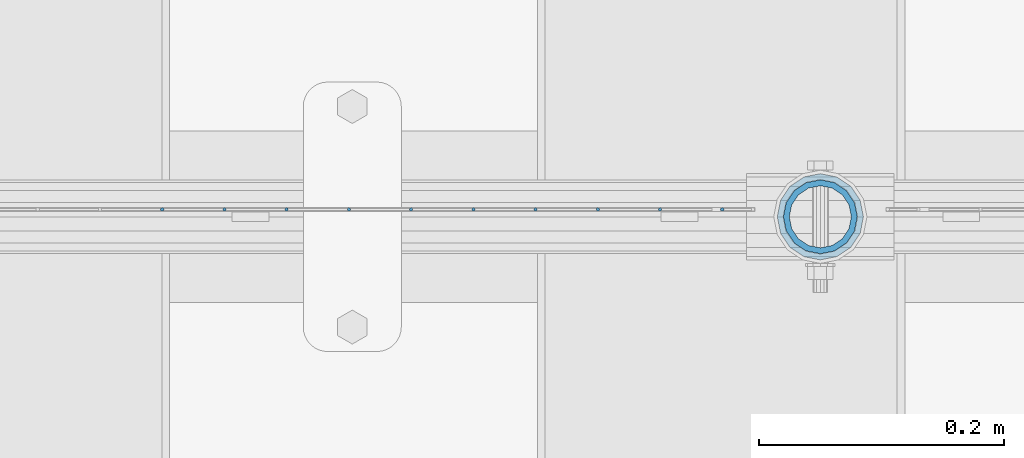
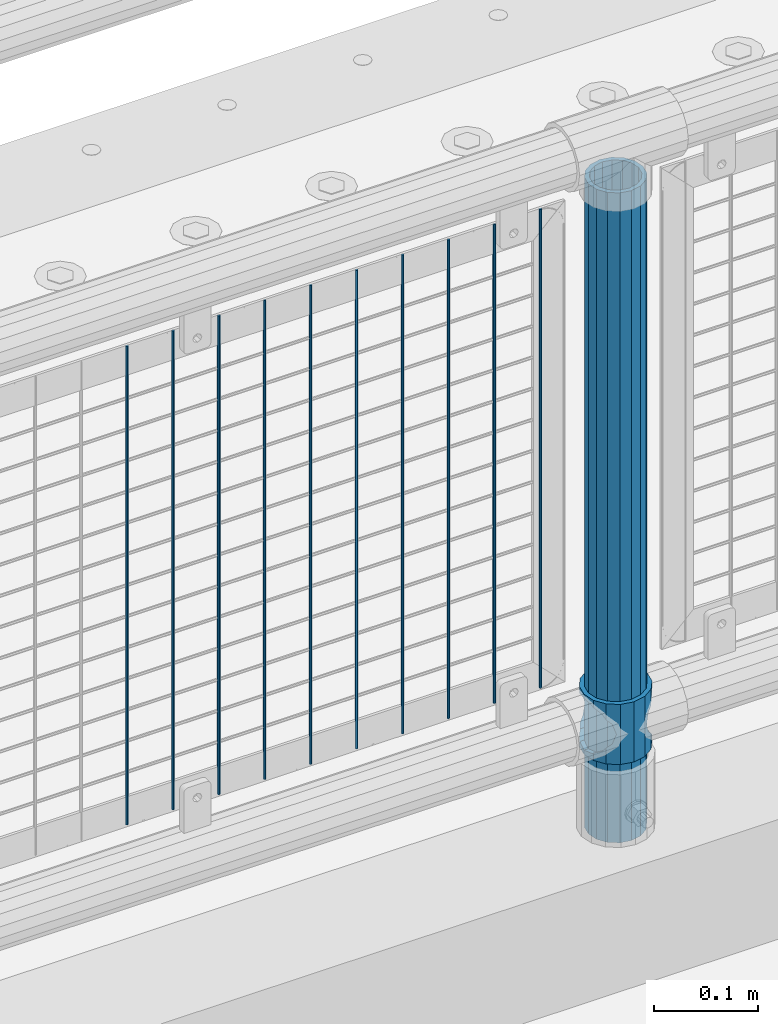
# One storey, part 99 of 242: 12 columns.
"""IFC2X3 building model written with IfcOpenShell, lengths in millimetres."""

from ifc_helpers import new_model, si_unit, frame, origin_with_axes, place, context, subcontext, project, spatial, faceted_brep, material, type_object, element, save


model = new_model("IFC2X3")

# Units and contexts
model_context = context("Model", 3, precision=1e-05, world=origin_with_axes())
body_context = subcontext(model_context, "Body", "Model", "MODEL_VIEW")
ifc_project = project(units=[si_unit("LENGTHUNIT", "METRE", prefix="MILLI"), si_unit("AREAUNIT", "SQUARE_METRE"), si_unit("VOLUMEUNIT", "CUBIC_METRE"), si_unit("MASSUNIT", "GRAM", prefix="KILO"), si_unit("TIMEUNIT", "SECOND"), si_unit("PLANEANGLEUNIT", "RADIAN"), si_unit("SOLIDANGLEUNIT", "STERADIAN"), si_unit("THERMODYNAMICTEMPERATUREUNIT", "DEGREE_CELSIUS"), si_unit("LUMINOUSINTENSITYUNIT", "LUMEN")], contexts=[model_context])

# Site, building, storey
site_placement = place(None, origin_with_axes())
site = spatial("IfcSite", under=ifc_project, at=site_placement, CompositionType="ELEMENT")
building_placement = place(site_placement, origin_with_axes())
building = spatial("IfcBuilding", under=site, at=building_placement, Name="Standard", CompositionType="ELEMENT")
storey_placement = place(building_placement, origin_with_axes())
storey = spatial("IfcBuildingStorey", under=building, at=storey_placement, Name="Undefined", CompositionType="ELEMENT", Elevation=0.0)

# Columns
ifc_material_1 = material()
column_type_1 = type_object("IfcColumnType", PredefinedType="NOTDEFINED")
column_1_placement = place(storey_placement, frame((-25499.0, -19335.5, 168.02), z_axis=(-1.0, 0.0, 0.0), x_axis=(0.0, 0.0, 1.0)))
element("IfcColumn", 1, at=column_1_placement, inside=storey, type_object=column_type_1, material=ifc_material_1, context=body_context, shape_type="Brep", body=[
    faceted_brep([(0.0, -25.3499999999985, 0.0), (0.0, -23.4203461491597, 9.70102501045403), (760.0, -23.4203461491597, 9.70102501045403), (760.0, -25.3499999999985, 0.0), (0.0, -17.9251569030785, 17.9251569030785), (760.0, -17.9251569030785, 17.9251569030785), (0.0, -9.70102501045403, 23.4203461491597), (760.0, -9.70102501045403, 23.4203461491597), (0.0, 0.0, 25.3499999999985), (760.0, 0.0, 25.3499999999985), (0.0, 9.70102501045403, 23.4203461491597), (760.0, 9.70102501045403, 23.4203461491597), (0.0, 17.9251569030785, 17.9251569030785), (760.0, 17.9251569030785, 17.9251569030785), (0.0, 23.4203461491597, 9.70102501045403), (760.0, 23.4203461491597, 9.70102501045403), (0.0, 25.3499999999985, 0.0), (760.0, 25.3499999999985, 0.0), (0.0, 23.4203461491597, -9.70102501045403), (760.0, 23.4203461491597, -9.70102501045403), (0.0, 17.9251569030785, -17.9251569030785), (760.0, 17.9251569030785, -17.9251569030785), (0.0, 9.70102501045403, -23.4203461491597), (760.0, 9.70102501045403, -23.4203461491597), (0.0, 0.0, -25.3499999999985), (760.0, 0.0, -25.3499999999985), (0.0, -9.70102501045403, -23.4203461491597), (760.0, -9.70102501045403, -23.4203461491597), (0.0, -17.9251569030785, -17.9251569030785), (760.0, -17.9251569030785, -17.9251569030785), (0.0, -23.4203461491597, -9.70102501045403), (760.0, -23.4203461491597, -9.70102501045403), (0.0, -30.1500000000015, 0.0), (0.0, -27.8549679052157, -11.5379054858058), (760.0, -27.8549679052157, -11.5379054858058), (760.0, -30.1500000000015, 0.0), (0.0, -21.3192694527752, -21.3192694527752), (760.0, -21.3192694527752, -21.3192694527752), (0.0, -11.5379054858058, -27.8549679052157), (760.0, -11.5379054858058, -27.8549679052157), (0.0, 0.0, -30.1500000000015), (760.0, 0.0, -30.1500000000015), (0.0, 11.5379054858058, -27.8549679052157), (760.0, 11.5379054858058, -27.8549679052157), (0.0, 21.3192694527752, -21.3192694527752), (760.0, 21.3192694527752, -21.3192694527752), (0.0, 27.8549679052157, -11.5379054858058), (760.0, 27.8549679052157, -11.5379054858058), (0.0, 30.1500000000015, 0.0), (760.0, 30.1500000000015, 0.0), (0.0, 27.8549679052157, 11.5379054858058), (760.0, 27.8549679052157, 11.5379054858058), (0.0, 21.3192694527752, 21.3192694527752), (760.0, 21.3192694527752, 21.3192694527752), (0.0, 11.5379054858058, 27.8549679052157), (760.0, 11.5379054858058, 27.8549679052157), (0.0, 0.0, 30.1500000000015), (760.0, 0.0, 30.1500000000015), (0.0, -11.5379054858058, 27.8549679052157), (760.0, -11.5379054858058, 27.8549679052157), (0.0, -21.3192694527752, 21.3192694527752), (760.0, -21.3192694527752, 21.3192694527752), (0.0, -27.8549679052157, 11.5379054858058), (760.0, -27.8549679052157, 11.5379054858058)], [[[0, 1, 2, 3]], [[1, 4, 5, 2]], [[4, 6, 7, 5]], [[6, 8, 9, 7]], [[8, 10, 11, 9]], [[10, 12, 13, 11]], [[12, 14, 15, 13]], [[14, 16, 17, 15]], [[16, 18, 19, 17]], [[18, 20, 21, 19]], [[20, 22, 23, 21]], [[22, 24, 25, 23]], [[24, 26, 27, 25]], [[26, 28, 29, 27]], [[28, 30, 31, 29]], [[30, 0, 3, 31]], [[32, 33, 34, 35]], [[33, 36, 37, 34]], [[36, 38, 39, 37]], [[38, 40, 41, 39]], [[40, 42, 43, 41]], [[42, 44, 45, 43]], [[44, 46, 47, 45]], [[46, 48, 49, 47]], [[48, 50, 51, 49]], [[50, 52, 53, 51]], [[52, 54, 55, 53]], [[54, 56, 57, 55]], [[56, 58, 59, 57]], [[58, 60, 61, 59]], [[60, 62, 63, 61]], [[62, 32, 35, 63]], [[37, 39, 41, 43, 45, 47, 49, 51, 53, 55, 57, 59, 61, 63, 35, 34], [5, 7, 9, 11, 13, 15, 17, 19, 21, 23, 25, 27, 29, 31, 3, 2]], [[62, 60, 58, 56, 54, 52, 50, 48, 46, 44, 42, 40, 38, 36, 33, 32], [30, 28, 26, 24, 22, 20, 18, 16, 14, 12, 10, 8, 6, 4, 1, 0]]]),
])
ifc_material_2 = material(Name="Misc_Undefined")
column_type_2 = type_object("IfcColumnType", PredefinedType="NOTDEFINED")
column_2_placement = place(storey_placement, frame((-25499.0, -19335.5, 263.02), z_axis=(-1.0, 0.0, 0.0), x_axis=(0.0, 0.0, 1.0)))
element("IfcColumn", 2, at=column_2_placement, inside=storey, type_object=column_type_2, material=ifc_material_2, context=body_context, shape_type="Brep", body=[
    faceted_brep([(63.1897438117172, 11.614442172282, -32.8397438117245), (63.1897438117172, 11.614442172282, -28.0397438117143), (56.6106908090114, 21.46069080901, -21.4606908090136), (56.6106908090114, 21.46069080901, -27.1226768591077), (61.9623795176744, 13.4513226476338, -32.4743655677739), (46.7644421722801, 28.0397438117179, -11.6144421722784), (46.7644421722801, 28.0397438117179, -20.0882031229849), (51.5310424080006, 24.8548033587067, -24.8548033587067), (35.1500000000015, 30.35, 0.0), (35.1499999999996, 30.3499999999985, -16.6306603983685), (23.5355578277192, 28.0397438117179, -11.6144421722784), (23.5355578277192, 28.0397438117179, -20.0882031229849), (18.7689575919987, 24.8548033587067, -24.8548033587067), (13.6893091909879, 21.46069080901, -21.4606908090136), (13.6893091909879, 21.46069080901, -27.1226768591077), (8.33762048232262, 13.4513226476338, -32.4743655677739), (7.11025618828211, 11.614442172282, -28.0397438117143), (7.11025618828211, 11.614442172282, -32.8397438117245), (4.79999999999961, 0.0, -30.3499999999985), (4.79999999999961, 0.0, -35.1500000000015), (7.11025618828211, -11.614442172282, -28.0397438117143), (7.11025618828211, -11.614442172282, -32.8397438117172), (13.6893091909879, -21.46069080901, -21.4606908090136), (13.6893091909879, -21.46069080901, -27.1226768591077), (8.33762048232484, -13.4513226476338, -32.4743655677739), (23.5355578277191, -28.0397438117179, -11.6144421722784), (23.5355578277191, -28.0397438117179, -20.0882031229921), (18.7689575919975, -24.8548033587067, -24.8548033587067), (35.1500000000015, -30.35, 0.0), (35.1499999999996, -30.3499999999985, -16.6306603983758), (46.7644421722801, -28.0397438117179, -11.6144421722784), (46.7644421722801, -28.0397438117179, -20.0882031229921), (51.5310424079973, -24.8548033587067, -24.8548033587067), (56.6106908090114, -21.46069080901, -21.4606908090136), (56.6106908090114, -21.46069080901, -27.1226768591077), (61.9623795176767, -13.4513226476338, -32.4743655677739), (63.1897438117172, -11.614442172282, -28.0397438117143), (63.1897438117172, -11.614442172282, -32.8397438117172), (65.4999999999997, 0.0, -30.3499999999985), (65.4999999999997, 0.0, -35.1500000000015), (0.0, -28.0397438117179, -11.6144421722784), (0.0, -30.3499999999985, 0.0), (0.0, -21.46069080901, -21.4606908090136), (0.0, -11.614442172282, -28.0397438117143), (0.0, 0.0, -30.3499999999985), (0.0, 11.614442172282, -28.0397438117143), (0.0, 21.46069080901, -21.4606908090136), (0.0, 28.0397438117179, -11.6144421722784), (0.0, 30.3499999999985, 0.0), (0.0, 28.0397438117179, 11.6144421722784), (23.5355578277192, 28.0397438117179, 11.614442172282), (0.0, 21.46069080901, 21.4606908090136), (13.6893091909879, 21.46069080901, 21.46069080901), (0.0, 11.614442172282, 28.0397438117143), (7.11025618828211, 11.614442172282, 28.0397438117179), (0.0, 0.0, 30.3499999999985), (4.79999999999961, 0.0, 30.3499999999985), (0.0, -11.614442172282, 28.0397438117143), (7.11025618828205, -11.614442172282, 28.0397438117179), (0.0, -21.46069080901, 21.4606908090136), (13.6893091909879, -21.46069080901, 21.46069080901), (0.0, -28.0397438117179, 11.6144421722784), (23.5355578277191, -28.0397438117179, 11.614442172282), (0.0, -32.4743655677703, 13.4513226476338), (0.0, -35.1500000000015, 0.0), (70.2999999999993, -35.1500000000015, 0.0), (70.2999999999993, -32.4743655677703, 13.4513226476338), (0.0, 13.4513226476338, -32.4743655677739), (0.0, 24.8548033587067, -24.8548033587067), (0.0, 0.0, -35.1500000000015), (0.0, -13.4513226476338, -32.4743655677739), (0.0, -24.8548033587067, -24.8548033587067), (0.0, -24.8548033587067, 24.8548033587067), (0.0, -13.4513226476338, 32.4743655677739), (0.0, 0.0, 35.1500000000015), (0.0, 13.4513226476338, 32.4743655677739), (0.0, 24.8548033587067, 24.8548033587067), (0.0, 32.4743655677703, 13.4513226476338), (0.0, 35.1500000000015, 0.0), (0.0, 32.4743655677703, -13.4513226476338), (0.0, -32.4743655677703, -13.4513226476338), (70.2999999999993, 32.4743655677703, 13.4513226476338), (70.2999999999993, 35.1500000000015, 0.0), (70.2999999999993, 32.4743655677703, -13.4513226476338), (70.2999999999993, 24.8548033587067, -24.8548033587067), (70.2999999999993, 13.4513226476338, -32.4743655677739), (70.2999999999993, 0.0, -35.1500000000015), (70.2999999999993, -13.4513226476338, -32.4743655677739), (70.2999999999993, -24.8548033587067, -24.8548033587067), (70.2999999999993, -32.4743655677703, -13.4513226476338), (70.2999999999993, 28.0397438117179, 11.6144421722784), (70.2999999999993, 21.46069080901, 21.4606908090136), (56.6106908090114, 21.46069080901, 21.46069080901), (46.7644421722801, 28.0397438117179, 11.614442172282), (70.2999999999993, 11.614442172282, 28.0397438117143), (63.1897438117172, 11.614442172282, 28.0397438117179), (70.2999999999993, 0.0, 30.3499999999985), (65.4999999999997, 0.0, 30.3499999999985), (70.2999999999993, -11.614442172282, 28.0397438117143), (63.1897438117172, -11.614442172282, 28.0397438117179), (70.2999999999993, -21.46069080901, 21.4606908090136), (56.6106908090114, -21.46069080901, 21.46069080901), (70.2999999999993, -28.0397438117179, 11.6144421722784), (46.7644421722801, -28.0397438117179, 11.614442172282), (70.2999999999993, -11.614442172282, -28.0397438117143), (70.2999999999993, 0.0, -30.3499999999985), (70.2999999999993, -21.46069080901, -21.4606908090136), (70.2999999999993, -28.0397438117179, -11.6144421722784), (70.2999999999993, -30.3499999999985, 0.0), (70.2999999999993, 24.8548033587067, 24.8548033587067), (70.2999999999993, 13.4513226476338, 32.4743655677739), (70.2999999999993, 0.0, 35.1500000000015), (70.2999999999993, -13.4513226476338, 32.4743655677739), (70.2999999999993, -24.8548033587067, 24.8548033587067), (70.2999999999993, 30.3499999999985, 0.0), (70.2999999999993, 28.0397438117179, -11.6144421722784), (70.2999999999993, 21.46069080901, -21.4606908090136), (70.2999999999993, 11.614442172282, -28.0397438117143), (61.9623795176744, 13.4513226476338, 32.4743655677703), (51.5310424080006, 24.8548033587067, 24.8548033587067), (56.6106908090114, 21.46069080901, 27.1226768591077), (65.4999999999997, 0.0, 35.1500000000015), (63.1897438117172, 11.614442172282, 32.8397438117136), (63.1897438117172, -11.614442172282, 32.8397438117172), (61.9623795176767, -13.4513226476338, 32.4743655677703), (56.6106908090114, -21.46069080901, 27.1226768591077), (51.5310424080038, -24.8548033587067, 24.8548033587067), (18.7689575919954, -24.8548033587067, 24.8548033587067), (46.7644421722801, -28.0397438117179, 20.0882031229885), (35.1499999999996, -30.3499999999985, 16.6306603983685), (23.5355578277191, -28.0397438117179, 20.0882031229885), (8.33762048232484, -13.4513226476338, 32.4743655677703), (13.6893091909879, -21.46069080901, 27.1226768591077), (4.79999999999961, 0.0, 35.1500000000015), (7.11025618828205, -11.614442172282, 32.8397438117172), (7.11025618828211, 11.614442172282, 32.8397438117136), (8.33762048232262, 13.4513226476338, 32.4743655677703), (13.6893091909879, 21.46069080901, 27.1226768591077), (18.768957592002, 24.8548033587067, 24.8548033587067), (23.5355578277192, 28.0397438117179, 20.0882031229812), (35.1499999999996, 30.3499999999985, 16.6306603983721), (46.7644421722801, 28.0397438117179, 20.0882031229812)], [[[0, 1, 2, 3, 4]], [[3, 2, 5, 6, 7]], [[6, 5, 8, 9]], [[9, 8, 10, 11]], [[12, 11, 10, 13, 14]], [[15, 14, 13, 16, 17]], [[17, 16, 18, 19]], [[19, 18, 20, 21]], [[21, 20, 22, 23, 24]], [[23, 22, 25, 26, 27]], [[26, 25, 28, 29]], [[29, 28, 30, 31]], [[32, 31, 30, 33, 34]], [[35, 34, 33, 36, 37]], [[37, 36, 38, 39]], [[39, 38, 1, 0]], [[40, 41, 28, 25]], [[42, 40, 25, 22]], [[43, 42, 22, 20]], [[44, 43, 20, 18]], [[45, 44, 18, 16]], [[46, 45, 16, 13]], [[47, 46, 13, 10]], [[48, 47, 10, 8]], [[49, 48, 8, 50]], [[51, 49, 50, 52]], [[53, 51, 52, 54]], [[55, 53, 54, 56]], [[57, 55, 56, 58]], [[59, 57, 58, 60]], [[61, 59, 60, 62]], [[41, 61, 62, 28]], [[63, 64, 65, 66]], [[67, 68, 12, 14, 15]], [[69, 67, 15, 17, 19]], [[24, 70, 69, 19, 21]], [[27, 71, 70, 24, 23]], [[63, 72, 73, 74, 75, 76, 77, 78, 79, 68, 67, 69, 70, 71, 80, 64], [40, 42, 43, 44, 45, 46, 47, 48, 49, 51, 53, 55, 57, 59, 61, 41]], [[78, 77, 81, 82]], [[79, 78, 82, 83]], [[68, 79, 83, 84, 7, 6, 9, 11, 12]], [[7, 84, 85, 4, 3]], [[4, 85, 86, 39, 0]], [[87, 88, 32, 34, 35]], [[86, 87, 35, 37, 39]], [[29, 31, 32, 88, 89, 80, 71, 27, 26]], [[64, 80, 89, 65]], [[90, 91, 92, 93]], [[91, 94, 95, 92]], [[94, 96, 97, 95]], [[96, 98, 99, 97]], [[98, 100, 101, 99]], [[100, 102, 103, 101]], [[104, 105, 38, 36]], [[106, 104, 36, 33]], [[107, 106, 33, 30]], [[108, 107, 30, 28]], [[102, 108, 28, 103]], [[88, 87, 86, 85, 84, 83, 82, 81, 109, 110, 111, 112, 113, 66, 65, 89], [100, 98, 96, 94, 91, 90, 114, 115, 116, 117, 105, 104, 106, 107, 108, 102]], [[118, 110, 109, 119, 120]], [[121, 111, 110, 118, 122]], [[112, 111, 121, 123, 124]], [[113, 112, 124, 125, 126]], [[127, 72, 63, 66, 113, 126, 128, 129, 130]], [[131, 73, 72, 127, 132]], [[133, 74, 73, 131, 134]], [[75, 74, 133, 135, 136]], [[76, 75, 136, 137, 138]], [[119, 109, 81, 77, 76, 138, 139, 140, 141]], [[92, 120, 119, 141, 93]], [[95, 122, 118, 120, 92]], [[97, 121, 122, 95]], [[99, 123, 121, 97]], [[101, 125, 124, 123, 99]], [[103, 128, 126, 125, 101]], [[28, 129, 128, 103]], [[62, 130, 129, 28]], [[60, 132, 127, 130, 62]], [[58, 134, 131, 132, 60]], [[56, 133, 134, 58]], [[54, 135, 133, 56]], [[52, 137, 136, 135, 54]], [[50, 139, 138, 137, 52]], [[8, 140, 139, 50]], [[93, 141, 140, 8]], [[114, 90, 93, 8]], [[115, 114, 8, 5]], [[116, 115, 5, 2]], [[117, 116, 2, 1]], [[105, 117, 1, 38]]]),
])
column_type_3 = type_object("IfcColumnType", Name="D3", PredefinedType="NOTDEFINED")
for number, where, z_axis, x_axis in (
    (3, (-25629.796, -19329.5, 353.02), (-1.0, 0.0, 0.0), (0.0, 0.0, 1.0)),
    (4, (-25680.589, -19329.5, 353.02), (-1.0, 0.0, 0.0), (0.0, 0.0, 1.0)),
    (5, (-25731.382, -19329.5, 353.02), (-1.0, 0.0, 0.0), (0.0, 0.0, 1.0)),
    (6, (-25782.175, -19329.5, 353.02), (-1.0, 0.0, 0.0), (0.0, 0.0, 1.0)),
    (7, (-25832.968, -19329.5, 353.02), (-1.0, 0.0, 0.0), (0.0, 0.0, 1.0)),
    (8, (-25883.761, -19329.5, 353.02), (-1.0, 0.0, 0.0), (0.0, 0.0, 1.0)),
    (9, (-25934.554, -19329.5, 353.02), (-1.0, 0.0, 0.0), (0.0, 0.0, 1.0)),
    (10, (-25579.003, -19329.5, 353.02), (-1.0, 0.0, 0.0), (0.0, 0.0, 1.0)),
    (11, (-25985.347, -19329.5, 353.02), (-1.0, 0.0, 0.0), (0.0, 0.0, 1.0)),
    (12, (-26036.14, -19329.5, 353.02), (-1.0, 0.0, 0.0), (0.0, 0.0, 1.0)),
):
    element("IfcColumn", number, at=place(storey_placement, frame(where, z_axis=z_axis, x_axis=x_axis)), inside=storey, type_object=column_type_3, material=ifc_material_2, ObjectType="D3", context=body_context, shape_type="Brep", body=[
        faceted_brep([(0.0, -1.50000000000364, 0.0), (-3.63797880709171e-12, -0.750000000003638, -1.29903810567669), (560.0, -0.75, -1.29903810567703), (560.0, -1.5, 0.0), (0.0, 0.749999999996362, -1.29903810567669), (560.0, 0.75, -1.29903810567703), (-3.63797880709171e-12, 1.49999999999636, 0.0), (560.0, 1.5, 0.0), (0.0, 0.749999999996362, 1.29903810567669), (560.0, 0.75, 1.29903810567703), (-3.63797880709171e-12, -0.750000000003638, 1.29903810567669), (560.0, -0.75, 1.29903810567703)], [[[0, 1, 2, 3]], [[1, 4, 5, 2]], [[4, 6, 7, 5]], [[6, 8, 9, 7]], [[8, 10, 11, 9]], [[10, 0, 3, 11]], [[5, 7, 9, 11, 3, 2]], [[10, 8, 6, 4, 1, 0]]]),
    ])

save(model, "model.ifc")
